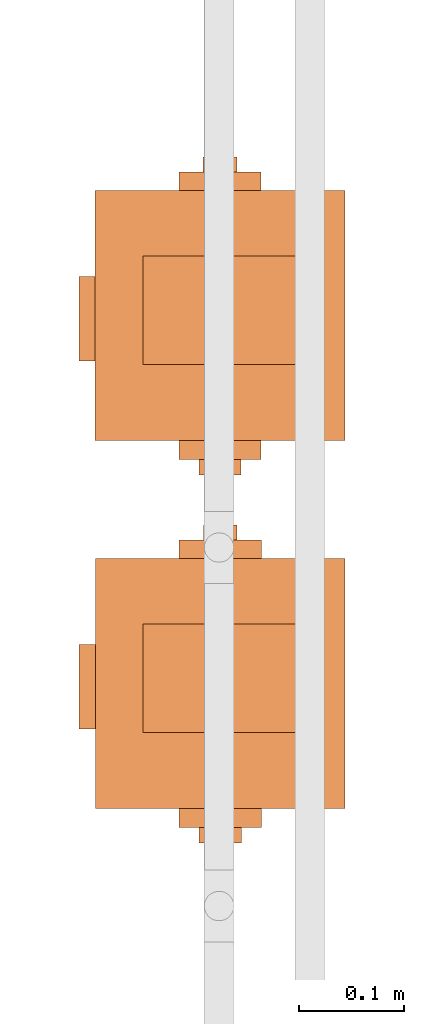
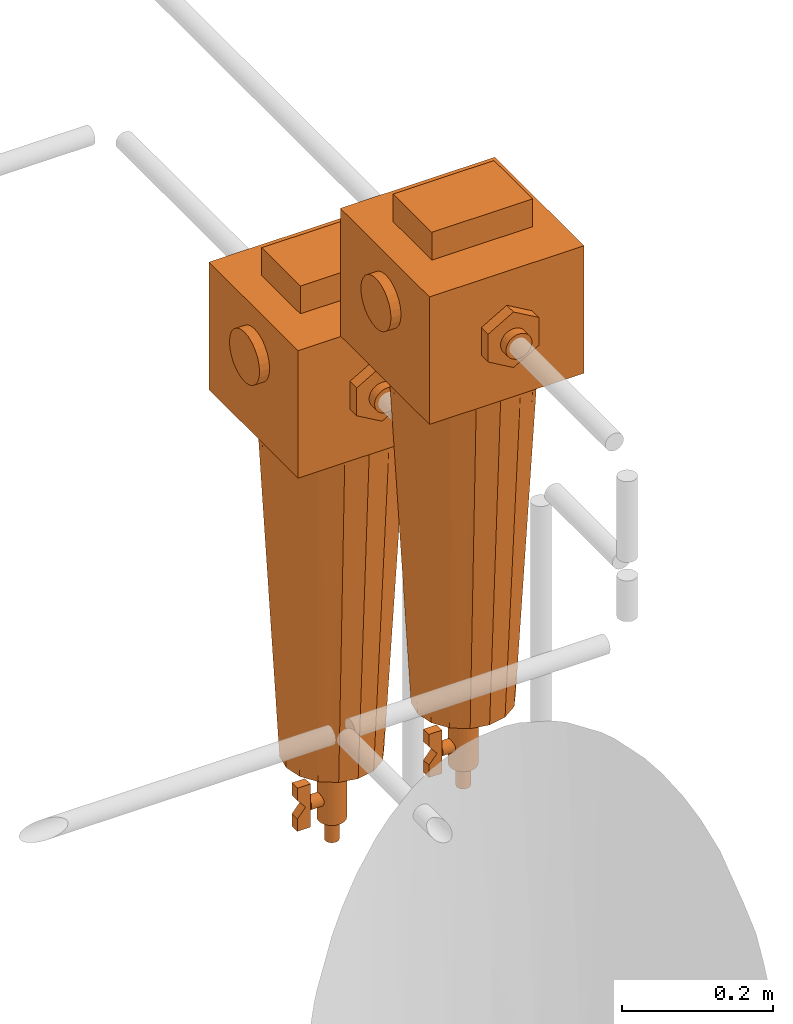
# One storey, part 331 of 331: 2 proxies.
"""IFC2X3 building model written with IfcOpenShell, lengths in millimetres."""

from ifc_helpers import new_model, entity, si_unit, converted_unit, derived_unit, direction, frame, origin, place, context, subcontext, project, spatial, faceted_brep, source, transform, mapped, material, material_list, type_object, type_shapes, element, save


model = new_model("IFC2X3")

# Units and contexts
model_context = context("Model", 3, precision=0.01, world=origin(), true_north=direction((6.12303176911189e-17, 1.0)))
body_context = subcontext(model_context, "Body", "Model", "MODEL_VIEW")
ifc_project = project(units=[si_unit("LENGTHUNIT", "METRE", prefix="MILLI"), si_unit("AREAUNIT", "SQUARE_METRE"), si_unit("VOLUMEUNIT", "CUBIC_METRE"), converted_unit("PLANEANGLEUNIT", "DEGREE", entity("IfcRatioMeasure", 0.0174532925199433), si_unit("PLANEANGLEUNIT", "RADIAN"), dimensions=[0, 0, 0, 0, 0, 0, 0]), si_unit("MASSUNIT", "GRAM", prefix="KILO"), derived_unit("MASSDENSITYUNIT", [(si_unit("MASSUNIT", "GRAM", prefix="KILO"), 1), (si_unit("LENGTHUNIT", "METRE"), -3)]), derived_unit("MOMENTOFINERTIAUNIT", [(si_unit("LENGTHUNIT", "METRE"), 4)]), si_unit("TIMEUNIT", "SECOND"), si_unit("FREQUENCYUNIT", "HERTZ"), si_unit("THERMODYNAMICTEMPERATUREUNIT", "DEGREE_CELSIUS"), derived_unit("THERMALTRANSMITTANCEUNIT", [(si_unit("MASSUNIT", "GRAM", prefix="KILO"), 1), (si_unit("THERMODYNAMICTEMPERATUREUNIT", "KELVIN"), -1), (si_unit("TIMEUNIT", "SECOND"), -3)]), derived_unit("VOLUMETRICFLOWRATEUNIT", [(si_unit("LENGTHUNIT", "METRE"), 3), (si_unit("TIMEUNIT", "SECOND"), -1)]), derived_unit("MASSFLOWRATEUNIT", [(si_unit("MASSUNIT", "GRAM", prefix="KILO"), 1), (si_unit("TIMEUNIT", "SECOND"), -1)]), derived_unit("ROTATIONALFREQUENCYUNIT", [(si_unit("TIMEUNIT", "SECOND"), -1)]), si_unit("ELECTRICCURRENTUNIT", "AMPERE"), si_unit("ELECTRICVOLTAGEUNIT", "VOLT"), si_unit("POWERUNIT", "WATT"), si_unit("FORCEUNIT", "NEWTON", prefix="KILO"), si_unit("ILLUMINANCEUNIT", "LUX"), si_unit("LUMINOUSFLUXUNIT", "LUMEN"), si_unit("LUMINOUSINTENSITYUNIT", "CANDELA"), derived_unit("USERDEFINED", [(si_unit("MASSUNIT", "GRAM", prefix="KILO"), -1), (si_unit("LENGTHUNIT", "METRE"), -2), (si_unit("TIMEUNIT", "SECOND"), 3), (si_unit("LUMINOUSFLUXUNIT", "LUMEN"), 1)]), derived_unit("LINEARVELOCITYUNIT", [(si_unit("LENGTHUNIT", "METRE"), 1), (si_unit("TIMEUNIT", "SECOND"), -1)]), si_unit("PRESSUREUNIT", "PASCAL"), derived_unit("USERDEFINED", [(si_unit("LENGTHUNIT", "METRE"), -2), (si_unit("MASSUNIT", "GRAM", prefix="KILO"), 1), (si_unit("TIMEUNIT", "SECOND"), -2)]), derived_unit("LINEARFORCEUNIT", [(si_unit("MASSUNIT", "GRAM", prefix="KILO"), 1), (si_unit("LENGTHUNIT", "METRE"), 1), (si_unit("TIMEUNIT", "SECOND"), -2), (si_unit("LENGTHUNIT", "METRE"), -1)]), derived_unit("PLANARFORCEUNIT", [(si_unit("MASSUNIT", "GRAM", prefix="KILO"), 1), (si_unit("LENGTHUNIT", "METRE"), 1), (si_unit("TIMEUNIT", "SECOND"), -2), (si_unit("LENGTHUNIT", "METRE"), -2)])], contexts=[model_context])

# Site, building, storey
site_placement = place(None, frame((0.0, -0.00077364408347762, 0.0)))
site = spatial("IfcSite", under=ifc_project, at=site_placement, CompositionType="ELEMENT")
building_placement = place(site_placement, origin())
building = spatial("IfcBuilding", under=site, at=building_placement, CompositionType="ELEMENT")
storey_placement = place(building_placement, origin())
storey = spatial("IfcBuildingStorey", under=building, at=storey_placement, CompositionType="ELEMENT", Elevation=0.0)

# Proxies
ifc_material_1 = material()
ifc_material_2 = material()
ifc_material_list_1 = material_list([ifc_material_1, ifc_material_2])
building_element_proxy_type = type_object("IfcBuildingElementProxyType", PredefinedType="NOTDEFINED", material=ifc_material_1)
shared_shape = source(origin(), body_context, "Body", "Brep", [
    faceted_brep([(0.0, -133.944326212679, 215.362410286268), (-10.3527618041006, -133.944326212679, 213.999443337831), (-20.0, -133.944326212679, 210.003426437646), (-28.2842712474617, -133.944326212679, 203.64668153373), (-34.6410161513774, -133.944326212679, 195.362410286268), (-38.6370330515627, -133.944326212679, 185.715172090369), (-40.0, -133.944326212679, 175.362410286268), (-38.6370330515627, -133.944326212679, 165.009648482167), (-34.6410161513776, -133.944326212679, 155.362410286268), (-28.2842712474619, -133.944326212679, 147.078139038806), (-20.0, -133.944326212679, 140.721394134891), (-10.3527618041009, -133.944326212679, 136.725377234705), (0.0, -133.944326212679, 135.362410286268), (10.3527618041008, -133.944326212679, 136.725377234705), (20.0, -133.944326212679, 140.721394134891), (28.2842712474618, -133.944326212679, 147.078139038806), (34.6410161513775, -133.944326212679, 155.362410286268), (38.6370330515627, -133.944326212679, 165.009648482167), (40.0, -133.944326212679, 175.362410286268), (38.6370330515628, -133.944326212679, 185.715172090369), (34.6410161513776, -133.944326212679, 195.362410286268), (28.284271247462, -133.944326212679, 203.64668153373), (20.0, -133.944326212679, 210.003426437646), (10.352761804101, -133.944326212679, 213.999443337831), (0.0, -118.499999999999, 135.362410286268), (-10.3527618041009, -118.499999999999, 136.725377234705), (-20.0, -118.499999999999, 140.721394134891), (-28.2842712474619, -118.499999999999, 147.078139038806), (-34.6410161513776, -118.499999999999, 155.362410286268), (-38.6370330515627, -118.499999999999, 165.009648482167), (-40.0, -118.499999999999, 175.362410286268), (-38.6370330515627, -118.499999999999, 185.715172090369), (-34.6410161513774, -118.499999999999, 195.362410286268), (-28.2842712474617, -118.499999999999, 203.64668153373), (-20.0, -118.499999999999, 210.003426437646), (-10.3527618041006, -118.499999999999, 213.999443337831), (0.0, -118.499999999999, 215.362410286268), (10.352761804101, -118.499999999999, 213.999443337831), (20.0, -118.499999999999, 210.003426437646), (28.284271247462, -118.499999999999, 203.64668153373), (34.6410161513776, -118.499999999999, 195.362410286268), (38.6370330515628, -118.499999999999, 185.715172090369), (40.0, -118.499999999999, 175.362410286268), (38.6370330515627, -118.499999999999, 165.009648482167), (34.6410161513775, -118.499999999999, 155.362410286268), (28.2842712474618, -118.499999999999, 147.078139038806), (20.0, -118.499999999999, 140.721394134891), (10.3527618041008, -118.499999999999, 136.725377234705)], [[[0, 1, 2, 3, 4, 5, 6, 7, 8, 9, 10, 11, 12, 13, 14, 15, 16, 17, 18, 19, 20, 21, 22, 23]], [[24, 25, 26, 27, 28, 29, 30, 31, 32, 33, 34, 35, 36, 37, 38, 39, 40, 41, 42, 43, 44, 45, 46, 47]], [[41, 19, 18, 42]], [[40, 20, 19, 41]], [[22, 21, 39, 38]], [[40, 39, 21, 20]], [[23, 22, 38, 37]], [[0, 23, 37, 36]], [[35, 1, 0, 36]], [[34, 2, 1, 35]], [[4, 3, 33, 32]], [[34, 33, 3, 2]], [[5, 4, 32, 31]], [[6, 5, 31, 30]], [[29, 7, 6, 30]], [[28, 8, 7, 29]], [[10, 9, 27, 26]], [[28, 27, 9, 8]], [[11, 10, 26, 25]], [[12, 11, 25, 24]], [[47, 13, 12, 24]], [[46, 14, 13, 47]], [[16, 15, 45, 44]], [[46, 45, 15, 14]], [[17, 16, 44, 43]], [[18, 17, 43, 42]]]),
    faceted_brep([(43.1099584355239, 81.5000000000009, 295.027035784925), (-59.5, 81.5000000000009, 295.027035784925), (-59.5, -73.1694472627613, 295.027035784925), (43.1099584355239, -73.1694472627613, 295.027035784925), (43.1099584355239, 81.5000000000009, 250.0), (43.1099584355239, -73.1694472627613, 250.0), (-59.5, -73.1694472627613, 250.0), (-59.5, 81.5000000000009, 250.0)], [[[0, 1, 2, 3]], [[4, 5, 6, 7]], [[1, 0, 4, 7]], [[2, 1, 7, 6]], [[3, 2, 6, 5]], [[0, 3, 5, 4]]]),
    faceted_brep([(6.83332917429858, -36.7004123407108, -547.095544544356), (6.83332917429858, -56.7004123407108, -547.095544544356), (6.83332917429858, -56.7004123407108, -567.095544544356), (6.83332917429858, -44.1139178730516, -582.095544544356), (6.83332917429858, -56.7004123407108, -597.095544544356), (6.83332917429858, -56.7004123407109, -617.095544544356), (6.83332917429858, -36.7004123407109, -617.095544544356), (6.83332917429858, -36.7004123407108, -582.095544544356), (-7.69905295378288, -36.7004123407108, -547.095544544356), (-7.69905295378288, -36.7004123407108, -582.095544544356), (-7.69905295378288, -36.7004123407109, -617.095544544356), (-7.69905295378288, -56.7004123407109, -617.095544544356), (-7.69905295378288, -56.7004123407108, -597.095544544356), (-7.69905295378288, -44.1139178730516, -582.095544544356), (-7.69905295378288, -56.7004123407108, -567.095544544356), (-7.69905295378288, -56.7004123407108, -547.095544544356)], [[[0, 1, 2, 3, 4, 5, 6, 7]], [[8, 9, 10, 11, 12, 13, 14, 15]], [[1, 0, 8, 15]], [[2, 1, 15, 14]], [[3, 2, 14, 13]], [[4, 3, 13, 12]], [[5, 4, 12, 11]], [[6, 5, 11, 10]], [[7, 6, 10, 9]], [[0, 7, 9, 8]]]),
    faceted_brep([(-5.0, -36.7004123407108, -573.435290506511), (-7.07106781186544, -36.7004123407108, -575.02447673249), (-8.66025403784436, -36.7004123407108, -577.095544544356), (-9.65925826289067, -36.7004123407108, -579.50735409333), (-10.0, -36.7004123407108, -582.095544544356), (-9.65925826289068, -36.7004123407108, -584.683734995381), (-8.66025403784439, -36.7004123407108, -587.095544544356), (-7.07106781186548, -36.7004123407108, -589.166612356221), (-5.0, -36.7004123407108, -590.7557985822), (-2.58819045102522, -36.7004123407108, -591.754802807246), (0.0, -36.7004123407108, -592.095544544356), (2.58819045102519, -36.7004123407108, -591.754802807246), (5.0, -36.7004123407108, -590.7557985822), (7.07106781186546, -36.7004123407108, -589.166612356221), (8.66025403784437, -36.7004123407108, -587.095544544356), (9.65925826289068, -36.7004123407108, -584.683734995381), (10.0, -36.7004123407108, -582.095544544356), (9.65925826289069, -36.7004123407108, -579.50735409333), (8.66025403784441, -36.7004123407108, -577.095544544356), (7.0710678118655, -36.7004123407108, -575.02447673249), (5.0, -36.7004123407108, -573.435290506511), (2.58819045102525, -36.7004123407108, -572.436286281465), (0.0, -36.7004123407108, -572.095544544356), (-2.58819045102516, -36.7004123407108, -572.436286281465), (2.58819045102519, -9.5868948994194, -591.754802807246), (0.0, -9.5868948994194, -592.095544544356), (-2.58819045102522, -9.5868948994194, -591.754802807246), (-5.0, -9.5868948994194, -590.7557985822), (-7.07106781186548, -9.5868948994194, -589.166612356221), (-8.66025403784439, -9.5868948994194, -587.095544544356), (-9.65925826289068, -9.5868948994194, -584.683734995381), (-10.0, -9.5868948994194, -582.095544544356), (-9.65925826289067, -9.5868948994194, -579.50735409333), (-8.66025403784436, -9.5868948994194, -577.095544544356), (-7.07106781186544, -9.5868948994194, -575.02447673249), (-5.0, -9.5868948994194, -573.435290506511), (-2.58819045102516, -9.5868948994194, -572.436286281465), (0.0, -9.5868948994194, -572.095544544356), (2.58819045102525, -9.5868948994194, -572.436286281465), (5.0, -9.5868948994194, -573.435290506511), (7.0710678118655, -9.5868948994194, -575.02447673249), (8.66025403784441, -9.5868948994194, -577.095544544356), (9.65925826289069, -9.5868948994194, -579.50735409333), (10.0, -9.5868948994194, -582.095544544356), (9.65925826289068, -9.5868948994194, -584.683734995381), (8.66025403784437, -9.5868948994194, -587.095544544356), (7.07106781186546, -9.5868948994194, -589.166612356221), (5.0, -9.5868948994194, -590.7557985822)], [[[0, 1, 2, 3, 4, 5, 6, 7, 8, 9, 10, 11, 12, 13, 14, 15, 16, 17, 18, 19, 20, 21, 22, 23]], [[24, 25, 26, 27, 28, 29, 30, 31, 32, 33, 34, 35, 36, 37, 38, 39, 40, 41, 42, 43, 44, 45, 46, 47]], [[42, 17, 16, 43]], [[41, 18, 17, 42]], [[20, 19, 40, 39]], [[41, 40, 19, 18]], [[21, 20, 39, 38]], [[22, 21, 38, 37]], [[36, 23, 22, 37]], [[35, 0, 23, 36]], [[2, 1, 34, 33]], [[35, 34, 1, 0]], [[3, 2, 33, 32]], [[4, 3, 32, 31]], [[30, 5, 4, 31]], [[29, 6, 5, 30]], [[8, 7, 28, 27]], [[29, 28, 7, 6]], [[9, 8, 27, 26]], [[10, 9, 26, 25]], [[24, 11, 10, 25]], [[47, 12, 11, 24]], [[14, 13, 46, 45]], [[47, 46, 13, 12]], [[15, 14, 45, 44]], [[16, 15, 44, 43]]]),
    faceted_brep([(5.17638090205032, -19.3185165257814, -545.770195770574), (10.0, -17.3205080756888, -545.770195770574), (14.1421356237309, -14.142135623731, -545.770195770574), (17.3205080756887, -10.0, -545.770195770574), (19.3185165257813, -5.17638090205054, -545.770195770574), (20.0, 0.0, -545.770195770574), (19.3185165257814, 5.17638090205041, -545.770195770574), (17.3205080756888, 10.0, -545.770195770574), (14.142135623731, 14.1421356237309, -545.770195770574), (10.0, 17.3205080756888, -545.770195770574), (5.17638090205044, 19.3185165257814, -545.770195770574), (0.0, 20.0, -545.770195770574), (-5.17638090205038, 19.3185165257814, -545.770195770574), (-10.0, 17.3205080756888, -545.770195770574), (-14.1421356237309, 14.142135623731, -545.770195770574), (-17.3205080756888, 10.0, -545.770195770574), (-19.3185165257814, 5.17638090205047, -545.770195770574), (-20.0, 0.0, -545.770195770574), (-19.3185165257814, -5.17638090205035, -545.770195770574), (-17.3205080756888, -10.0, -545.770195770574), (-14.142135623731, -14.1421356237309, -545.770195770574), (-10.0, -17.3205080756887, -545.770195770574), (-5.1763809020505, -19.3185165257813, -545.770195770574), (0.0, -20.0, -545.770195770574), (0.0, 20.0, -617.574154599676), (5.17638090205044, 19.3185165257814, -617.574154599676), (10.0, 17.3205080756888, -617.574154599676), (14.142135623731, 14.1421356237309, -617.574154599676), (17.3205080756888, 10.0, -617.574154599676), (19.3185165257814, 5.17638090205041, -617.574154599676), (20.0, 0.0, -617.574154599676), (19.3185165257813, -5.17638090205054, -617.574154599676), (17.3205080756887, -10.0, -617.574154599676), (14.1421356237309, -14.142135623731, -617.574154599676), (10.0, -17.3205080756888, -617.574154599676), (5.17638090205032, -19.3185165257814, -617.574154599676), (0.0, -20.0, -617.574154599676), (-5.1763809020505, -19.3185165257813, -617.574154599676), (-10.0, -17.3205080756887, -617.574154599676), (-14.142135623731, -14.1421356237309, -617.574154599676), (-17.3205080756888, -10.0, -617.574154599676), (-19.3185165257814, -5.17638090205035, -617.574154599676), (-20.0, 0.0, -617.574154599676), (-19.3185165257814, 5.17638090205047, -617.574154599676), (-17.3205080756888, 10.0, -617.574154599676), (-14.1421356237309, 14.142135623731, -617.574154599676), (-10.0, 17.3205080756888, -617.574154599676), (-5.17638090205038, 19.3185165257814, -617.574154599676)], [[[0, 1, 2, 3, 4, 5, 6, 7, 8, 9, 10, 11, 12, 13, 14, 15, 16, 17, 18, 19, 20, 21, 22, 23]], [[24, 25, 26, 27, 28, 29, 30, 31, 32, 33, 34, 35, 36, 37, 38, 39, 40, 41, 42, 43, 44, 45, 46, 47]], [[18, 41, 40, 19]], [[39, 20, 19, 40]], [[21, 38, 37, 22]], [[39, 38, 21, 20]], [[22, 37, 36, 23]], [[41, 18, 17, 42]], [[0, 35, 34, 1]], [[33, 2, 1, 34]], [[3, 32, 31, 4]], [[33, 32, 3, 2]], [[4, 31, 30, 5]], [[35, 0, 23, 36]], [[30, 29, 6, 5]], [[9, 26, 25, 10]], [[26, 9, 8, 27]], [[10, 25, 24, 11]], [[29, 28, 7, 6]], [[28, 27, 8, 7]], [[12, 47, 46, 13]], [[45, 14, 13, 46]], [[15, 44, 43, 16]], [[45, 44, 15, 14]], [[16, 43, 42, 17]], [[47, 12, 11, 24]]]),
    faceted_brep([(2.58819045102516, -9.6592582628907, -513.126445637314), (5.0, -8.66025403784441, -513.126445637314), (7.07106781186544, -7.07106781186551, -513.126445637314), (8.66025403784436, -5.0, -513.126445637314), (9.65925826289067, -2.58819045102527, -513.126445637314), (10.0, 0.0, -513.126445637314), (9.65925826289068, 2.58819045102521, -513.126445637314), (8.66025403784439, 5.0, -513.126445637314), (7.07106781186548, 7.07106781186547, -513.126445637314), (5.0, 8.66025403784438, -513.126445637314), (2.58819045102522, 9.65925826289068, -513.126445637314), (0.0, 10.0, -513.126445637314), (-2.58819045102519, 9.65925826289069, -513.126445637314), (-5.0, 8.6602540378444, -513.126445637314), (-7.07106781186546, 7.07106781186549, -513.126445637314), (-8.66025403784437, 5.0, -513.126445637314), (-9.65925826289068, 2.58819045102524, -513.126445637314), (-10.0, 0.0, -513.126445637314), (-9.65925826289069, -2.58819045102517, -513.126445637314), (-8.66025403784441, -5.0, -513.126445637314), (-7.0710678118655, -7.07106781186545, -513.126445637314), (-5.0, -8.66025403784437, -513.126445637314), (-2.58819045102525, -9.65925826289067, -513.126445637314), (0.0, -10.0, -513.126445637314), (0.0, 10.0, -652.602700358113), (2.58819045102522, 9.65925826289068, -652.602700358113), (5.0, 8.66025403784438, -652.602700358113), (7.07106781186548, 7.07106781186547, -652.602700358113), (8.66025403784439, 5.0, -652.602700358113), (9.65925826289068, 2.58819045102521, -652.602700358113), (10.0, 0.0, -652.602700358113), (9.65925826289067, -2.58819045102527, -652.602700358113), (8.66025403784436, -5.0, -652.602700358113), (7.07106781186544, -7.07106781186551, -652.602700358113), (5.0, -8.66025403784441, -652.602700358113), (2.58819045102516, -9.6592582628907, -652.602700358113), (0.0, -10.0, -652.602700358113), (-2.58819045102525, -9.65925826289067, -652.602700358113), (-5.0, -8.66025403784437, -652.602700358113), (-7.0710678118655, -7.07106781186545, -652.602700358113), (-8.66025403784441, -5.0, -652.602700358113), (-9.65925826289069, -2.58819045102517, -652.602700358113), (-10.0, 0.0, -652.602700358113), (-9.65925826289068, 2.58819045102524, -652.602700358113), (-8.66025403784437, 5.0, -652.602700358113), (-7.07106781186546, 7.07106781186549, -652.602700358113), (-5.0, 8.6602540378444, -652.602700358113), (-2.58819045102519, 9.65925826289069, -652.602700358113)], [[[0, 1, 2, 3, 4, 5, 6, 7, 8, 9, 10, 11, 12, 13, 14, 15, 16, 17, 18, 19, 20, 21, 22, 23]], [[24, 25, 26, 27, 28, 29, 30, 31, 32, 33, 34, 35, 36, 37, 38, 39, 40, 41, 42, 43, 44, 45, 46, 47]], [[41, 18, 17, 42]], [[40, 19, 18, 41]], [[21, 20, 39, 38]], [[40, 39, 20, 19]], [[22, 21, 38, 37]], [[23, 22, 37, 36]], [[35, 0, 23, 36]], [[3, 32, 31, 4]], [[32, 3, 2, 33]], [[4, 31, 30, 5]], [[0, 35, 34, 1]], [[1, 34, 33, 2]], [[29, 6, 5, 30]], [[28, 7, 6, 29]], [[9, 8, 27, 26]], [[28, 27, 8, 7]], [[9, 26, 25, 10]], [[24, 11, 10, 25]], [[14, 13, 46, 45]], [[15, 44, 43, 16]], [[45, 44, 15, 14]], [[16, 43, 42, 17]], [[47, 46, 13, 12]], [[12, 11, 24, 47]]]),
    faceted_brep([(-121.5, 0.0, 105.0), (-121.5, 38.9711431702997, 127.5), (-121.5, 38.9711431702998, 172.5), (-121.5, 0.0, 195.0), (-121.5, -38.9711431702996, 172.500000000001), (-121.5, -38.9711431702999, 127.500000000001), (-139.459825523657, 0.0, 105.0), (-139.459825523657, -38.9711431702999, 127.500000000001), (-139.459825523657, -38.9711431702996, 172.500000000001), (-139.459825523657, 0.0, 195.0), (-139.459825523657, 38.9711431702998, 172.5), (-139.459825523657, 38.9711431702997, 127.5)], [[[0, 1, 2, 3, 4, 5]], [[6, 7, 8, 9, 10, 11]], [[1, 0, 6, 11]], [[2, 1, 11, 10]], [[3, 2, 10, 9]], [[4, 3, 9, 8]], [[5, 4, 8, 7]], [[0, 5, 7, 6]]]),
    faceted_brep([(133.459825523657, 0.0, 105.0), (133.459825523657, 38.9711431702997, 127.5), (133.459825523657, 38.9711431702998, 172.5), (133.459825523657, 0.0, 195.0), (133.459825523657, -38.9711431702996, 172.5), (133.459825523657, -38.9711431702999, 127.5), (115.5, 0.0, 105.0), (115.5, -38.9711431702999, 127.5), (115.5, -38.9711431702996, 172.5), (115.5, 0.0, 195.0), (115.5, 38.9711431702998, 172.5), (115.5, 38.9711431702997, 127.5)], [[[0, 1, 2, 3, 4, 5]], [[6, 7, 8, 9, 10, 11]], [[1, 0, 6, 11]], [[2, 1, 11, 10]], [[3, 2, 10, 9]], [[4, 3, 9, 8]], [[5, 4, 8, 7]], [[0, 5, 7, 6]]]),
    faceted_brep([(-153.337340449734, 4.14110472164035, 162.941988222046), (-153.337340449734, 8.0, 161.343581461972), (-153.337340449734, 11.3137084989848, 158.800883500406), (-153.337340449734, 13.856406460551, 155.487175001421), (-153.337340449734, 15.4548132206251, 151.628279723061), (-153.337340449734, 16.0, 147.487175001421), (-153.337340449734, 15.4548132206251, 143.346070279781), (-153.337340449734, 13.856406460551, 139.487175001421), (-153.337340449734, 11.3137084989847, 136.173466502436), (-153.337340449734, 8.0, 133.63076854087), (-153.337340449734, 4.14110472164026, 132.032361780796), (-153.337340449734, 0.0, 131.487175001421), (-153.337340449734, -4.1411047216404, 132.032361780796), (-153.337340449734, -8.0, 133.63076854087), (-153.337340449734, -11.3137084989848, 136.173466502436), (-153.337340449734, -13.8564064605511, 139.487175001421), (-153.337340449734, -15.4548132206251, 143.346070279781), (-153.337340449734, -16.0, 147.487175001421), (-153.337340449734, -15.4548132206251, 151.628279723061), (-153.337340449734, -13.856406460551, 155.487175001421), (-153.337340449734, -11.3137084989847, 158.800883500406), (-153.337340449734, -8.0, 161.343581461972), (-153.337340449734, -4.14110472164031, 162.941988222046), (-153.337340449734, 0.0, 163.487175001421), (-139.459825523657, 4.14110472164026, 132.032361780796), (-139.459825523657, 8.0, 133.63076854087), (-139.459825523657, 11.3137084989847, 136.173466502436), (-139.459825523657, 13.856406460551, 139.487175001421), (-139.459825523657, 15.4548132206251, 143.346070279781), (-139.459825523657, 16.0, 147.487175001421), (-139.459825523657, 15.4548132206251, 151.628279723061), (-139.459825523657, 13.856406460551, 155.487175001421), (-139.459825523657, 11.3137084989848, 158.800883500406), (-139.459825523657, 8.0, 161.343581461972), (-139.459825523657, 4.14110472164035, 162.941988222046), (-139.459825523657, 0.0, 163.487175001421), (-139.459825523657, -4.14110472164031, 162.941988222046), (-139.459825523657, -8.0, 161.343581461972), (-139.459825523657, -11.3137084989847, 158.800883500406), (-139.459825523657, -13.856406460551, 155.487175001421), (-139.459825523657, -15.4548132206251, 151.628279723061), (-139.459825523657, -16.0, 147.487175001421), (-139.459825523657, -15.4548132206251, 143.346070279781), (-139.459825523657, -13.8564064605511, 139.487175001421), (-139.459825523657, -11.3137084989848, 136.173466502436), (-139.459825523657, -8.0, 133.63076854087), (-139.459825523657, -4.1411047216404, 132.032361780796), (-139.459825523657, 0.0, 131.487175001421)], [[[0, 1, 2, 3, 4, 5, 6, 7, 8, 9, 10, 11, 12, 13, 14, 15, 16, 17, 18, 19, 20, 21, 22, 23]], [[24, 25, 26, 27, 28, 29, 30, 31, 32, 33, 34, 35, 36, 37, 38, 39, 40, 41, 42, 43, 44, 45, 46, 47]], [[16, 42, 41, 17]], [[15, 43, 42, 16]], [[45, 44, 14, 13]], [[15, 14, 44, 43]], [[46, 45, 13, 12]], [[47, 46, 12, 11]], [[10, 24, 47, 11]], [[9, 25, 24, 10]], [[27, 26, 8, 7]], [[9, 8, 26, 25]], [[28, 27, 7, 6]], [[29, 28, 6, 5]], [[4, 30, 29, 5]], [[3, 31, 30, 4]], [[33, 32, 2, 1]], [[3, 2, 32, 31]], [[34, 33, 1, 0]], [[35, 34, 0, 23]], [[22, 36, 35, 23]], [[21, 37, 36, 22]], [[21, 20, 38, 37]], [[20, 19, 39, 38]], [[18, 40, 39, 19]], [[18, 17, 41, 40]]]),
    faceted_brep([(147.995639473242, -10.0, 165.507212653008), (147.995639473242, -14.1421356237309, 162.32884020105), (147.995639473242, -17.3205080756887, 158.186704577319), (147.995639473242, -19.3185165257813, 153.36308547937), (147.995639473242, -20.0, 148.186704577319), (147.995639473242, -19.3185165257814, 143.010323675269), (147.995639473242, -17.3205080756888, 138.186704577319), (147.995639473242, -14.142135623731, 134.044568953588), (147.995639473242, -10.0, 130.86619650163), (147.995639473242, -5.17638090205044, 128.868188051538), (147.995639473242, 0.0, 128.186704577319), (147.995639473242, 5.17638090205038, 128.868188051538), (147.995639473242, 10.0, 130.86619650163), (147.995639473242, 14.1421356237309, 134.044568953588), (147.995639473242, 17.3205080756888, 138.186704577319), (147.995639473242, 19.3185165257814, 143.010323675269), (147.995639473242, 20.0, 148.186704577319), (147.995639473242, 19.3185165257814, 153.363085479369), (147.995639473242, 17.3205080756888, 158.186704577319), (147.995639473242, 14.142135623731, 162.32884020105), (147.995639473242, 10.0, 165.507212653008), (147.995639473242, 5.1763809020505, 167.5052211031), (147.995639473242, 0.0, 168.186704577319), (147.995639473242, -5.17638090205032, 167.505221103101), (133.459825523657, 0.0, 128.186704577319), (133.459825523657, -5.17638090205044, 128.868188051538), (133.459825523657, -10.0, 130.86619650163), (133.459825523657, -14.142135623731, 134.044568953588), (133.459825523657, -17.3205080756888, 138.186704577319), (133.459825523657, -19.3185165257814, 143.010323675269), (133.459825523657, -20.0, 148.186704577319), (133.459825523657, -19.3185165257813, 153.36308547937), (133.459825523657, -17.3205080756887, 158.186704577319), (133.459825523657, -14.1421356237309, 162.32884020105), (133.459825523657, -10.0, 165.507212653008), (133.459825523657, -5.17638090205032, 167.505221103101), (133.459825523657, 0.0, 168.186704577319), (133.459825523657, 5.1763809020505, 167.5052211031), (133.459825523657, 10.0, 165.507212653008), (133.459825523657, 14.142135623731, 162.32884020105), (133.459825523657, 17.3205080756888, 158.186704577319), (133.459825523657, 19.3185165257814, 153.363085479369), (133.459825523657, 20.0, 148.186704577319), (133.459825523657, 19.3185165257814, 143.010323675269), (133.459825523657, 17.3205080756888, 138.186704577319), (133.459825523657, 14.1421356237309, 134.044568953588), (133.459825523657, 10.0, 130.86619650163), (133.459825523657, 5.17638090205038, 128.868188051538)], [[[0, 1, 2, 3, 4, 5, 6, 7, 8, 9, 10, 11, 12, 13, 14, 15, 16, 17, 18, 19, 20, 21, 22, 23]], [[24, 25, 26, 27, 28, 29, 30, 31, 32, 33, 34, 35, 36, 37, 38, 39, 40, 41, 42, 43, 44, 45, 46, 47]], [[41, 17, 16, 42]], [[40, 18, 17, 41]], [[20, 19, 39, 38]], [[40, 39, 19, 18]], [[21, 20, 38, 37]], [[22, 21, 37, 36]], [[35, 23, 22, 36]], [[34, 0, 23, 35]], [[2, 1, 33, 32]], [[34, 33, 1, 0]], [[3, 2, 32, 31]], [[4, 3, 31, 30]], [[29, 5, 4, 30]], [[28, 6, 5, 29]], [[8, 7, 27, 26]], [[28, 27, 7, 6]], [[9, 8, 26, 25]], [[10, 9, 25, 24]], [[47, 11, 10, 24]], [[46, 12, 11, 47]], [[45, 44, 14, 13]], [[46, 45, 13, 12]], [[15, 43, 42, 16]], [[15, 14, 44, 43]]]),
    faceted_brep([(-64.6715672757874, -26.7878402655554, -513.126445637314), (-67.3357836378922, -13.3939201327778, -513.126445637314), (-70.0, 0.0, -513.126445637314), (-67.3357836378947, 13.3939201327778, -513.126445637314), (-64.6715672757897, 26.7878402655559, -513.126445637314), (-57.0845209794239, 38.1426574743067, -513.126445637314), (-49.497474683058, 49.4974746830576, -513.126445637314), (-38.1426574743071, 57.0845209794232, -513.126445637314), (-26.7878402655561, 64.6715672757889, -513.126445637314), (-13.3939201327782, 67.3357836378936, -513.126445637314), (0.0, 70.0, -513.126445637314), (13.3939201327774, 67.3357836378933, -513.126445637314), (26.7878402655551, 64.6715672757882, -513.126445637314), (38.1426574743057, 57.0845209794225, -513.126445637314), (49.4974746830562, 49.4974746830568, -513.126445637314), (57.0845209794218, 38.1426574743062, -513.126445637314), (64.6715672757873, 26.7878402655556, -513.126445637314), (67.3357836378922, 13.393920132778, -513.126445637314), (70.0, 0.0, -513.126445637314), (67.3357836378946, -13.393920132778, -513.126445637314), (64.6715672757896, -26.7878402655561, -513.126445637314), (57.0845209794237, -38.1426574743069, -513.126445637314), (49.4974746830578, -49.4974746830577, -513.126445637314), (38.1426574743069, -57.0845209794233, -513.126445637314), (26.7878402655559, -64.6715672757889, -513.126445637314), (13.393920132778, -67.3357836378937, -513.126445637314), (0.0, -70.0, -513.126445637314), (-13.3939201327776, -67.3357836378932, -513.126445637314), (-26.7878402655553, -64.6715672757881, -513.126445637314), (-38.1426574743059, -57.0845209794224, -513.126445637314), (-49.4974746830564, -49.4974746830566, -513.126445637314), (-57.0845209794219, -38.142657474306, -513.126445637314), (-100.0, 0.0, 43.2779488123182), (-93.9692620785884, -34.2020143325663, 43.2779488123182), (-76.6044443118959, -64.2787609686527, 43.2779488123182), (-50.0, -86.6025403784423, 43.2779488123182), (-17.3648177666926, -98.4807753012194, 43.2779488123182), (17.364817766693, -98.4807753012198, 43.2779488123182), (50.0, -86.6025403784433, 43.2779488123182), (76.6044443118976, -64.2787609686537, 43.2779488123182), (93.9692620785908, -34.2020143325668, 43.2779488123182), (100.0, 0.0, 43.2779488123182), (93.9692620785883, 34.2020143325666, 43.2779488123182), (76.6044443118957, 64.2787609686529, 43.2779488123182), (50.0, 86.6025403784425, 43.2779488123182), (17.3648177666923, 98.4807753012194, 43.2779488123182), (-17.3648177666933, 98.4807753012197, 43.2779488123182), (-50.0, 86.6025403784431, 43.2779488123182), (-76.6044443118979, 64.2787609686534, 43.2779488123182), (-93.9692620785909, 34.2020143325665, 43.2779488123182)], [[[0, 1, 2, 3, 4, 5, 6, 7, 8, 9, 10, 11, 12, 13, 14, 15, 16, 17, 18, 19, 20, 21, 22, 23, 24, 25, 26, 27, 28, 29, 30, 31]], [[32, 33, 34, 35, 36, 37, 38, 39, 40, 41, 42, 43, 44, 45, 46, 47, 48, 49]], [[41, 17, 42]], [[11, 10, 45, 12]], [[44, 14, 13, 12]], [[15, 14, 43]], [[49, 4, 3]], [[42, 15, 43]], [[14, 44, 43]], [[15, 42, 16]], [[12, 45, 44]], [[46, 10, 9, 8]], [[17, 16, 42]], [[4, 49, 5]], [[17, 41, 18]], [[2, 32, 3]], [[6, 47, 8, 7]], [[8, 47, 46]], [[48, 6, 5]], [[6, 48, 47]], [[3, 32, 49]], [[48, 5, 49]], [[10, 46, 45]], [[32, 1, 33]], [[27, 26, 36, 28]], [[35, 30, 29, 28]], [[31, 30, 34]], [[40, 20, 19]], [[33, 31, 34]], [[30, 35, 34]], [[31, 33, 0]], [[28, 36, 35]], [[37, 26, 25, 24]], [[1, 0, 33]], [[20, 40, 21]], [[1, 32, 2]], [[18, 41, 19]], [[22, 38, 24, 23]], [[24, 38, 37]], [[39, 22, 21]], [[22, 39, 38]], [[19, 41, 40]], [[39, 21, 40]], [[26, 37, 36]]]),
    faceted_brep([(-121.5, 118.5, 250.0), (-121.5, -118.499999999999, 250.0), (115.5, -118.5, 250.0), (115.5, 118.5, 250.0), (-121.5, 118.5, 43.2779488123182), (115.5, 118.5, 43.2779488123182), (115.5, -118.5, 43.2779488123182), (-121.5, -118.499999999999, 43.2779488123182)], [[[0, 1, 2, 3]], [[4, 5, 6, 7]], [[1, 0, 4, 7]], [[2, 1, 7, 6]], [[3, 2, 6, 5]], [[0, 3, 5, 4]]]),
])
type_shapes(building_element_proxy_type, [shared_shape])
proxy_1_placement = place(storey_placement, frame((55671.5002685547, -1221.21770920486, 545.0), z_axis=(0.0, 0.0, 1.0), x_axis=(0.0, -1.0, 0.0)))
element("IfcBuildingElementProxy", 1, at=proxy_1_placement, inside=storey, type_object=building_element_proxy_type, material=ifc_material_list_1, context=body_context, shape_type="MappedRepresentation", body=[
    mapped(shared_shape, transform((0.0, 0.0, 0.0), scale=1.0)),
])
ifc_material_list_2 = material_list([ifc_material_1, ifc_material_2])
proxy_2_placement = place(storey_placement, frame((55671.6085349589, -1570.21481878437, 843.749999999999), z_axis=(0.0, 0.0, 1.0), x_axis=(0.0, -1.0, 0.0)))
element("IfcBuildingElementProxy", 2, at=proxy_2_placement, inside=storey, type_object=building_element_proxy_type, material=ifc_material_list_2, context=body_context, shape_type="MappedRepresentation", body=[
    mapped(shared_shape, transform((0.0, 0.0, 0.0), scale=1.0)),
])

save(model, "model.ifc")
